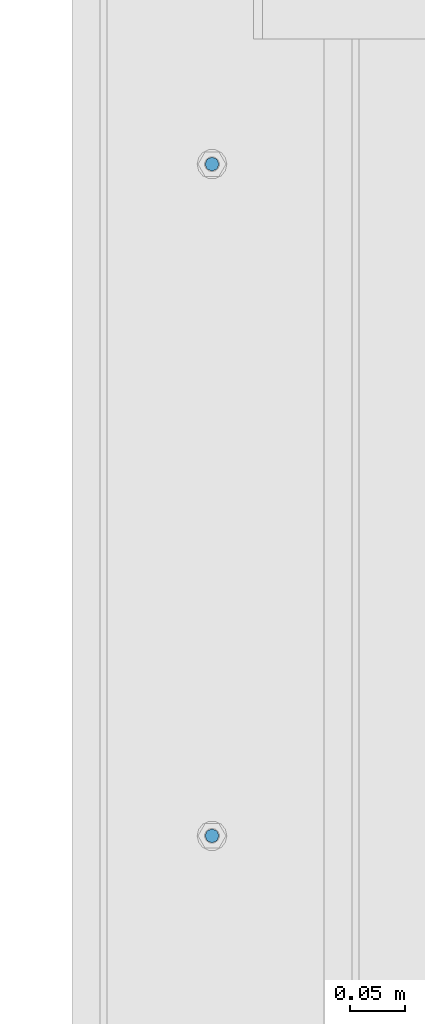
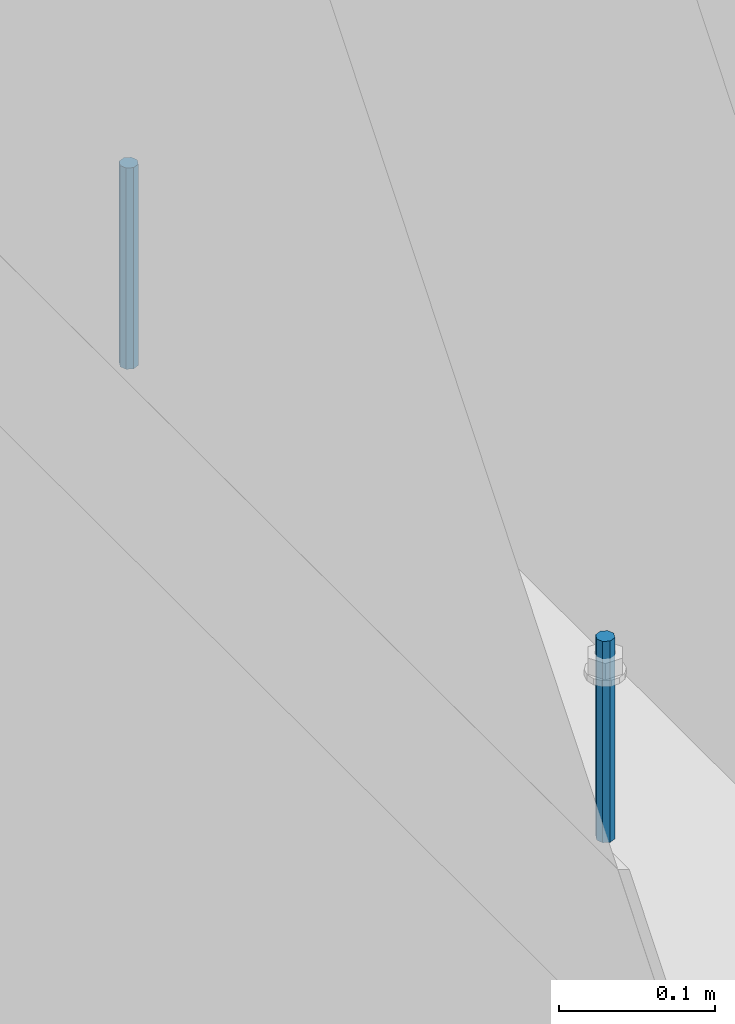
# One storey, part 383 of 1179: 2 columns, 1 element without a shape of its own.
"""IFC2X3 building model written with IfcOpenShell, lengths in millimetres."""

from ifc_helpers import new_model, si_unit, frame, origin_with_axes, place, context, subcontext, project, spatial, faceted_brep, material, type_object, element, aggregate, save


model = new_model("IFC2X3")

# Units and contexts
model_context = context("Model", 3, precision=1e-05, world=origin_with_axes())
body_context = subcontext(model_context, "Body", "Model", "MODEL_VIEW")
ifc_project = project(units=[si_unit("LENGTHUNIT", "METRE", prefix="MILLI"), si_unit("AREAUNIT", "SQUARE_METRE"), si_unit("VOLUMEUNIT", "CUBIC_METRE"), si_unit("MASSUNIT", "GRAM", prefix="KILO"), si_unit("TIMEUNIT", "SECOND"), si_unit("PLANEANGLEUNIT", "RADIAN"), si_unit("SOLIDANGLEUNIT", "STERADIAN"), si_unit("THERMODYNAMICTEMPERATUREUNIT", "DEGREE_CELSIUS"), si_unit("LUMINOUSINTENSITYUNIT", "LUMEN")], contexts=[model_context])

# Site, building, storey
site_placement = place(None, origin_with_axes())
site = spatial("IfcSite", under=ifc_project, at=site_placement, CompositionType="ELEMENT")
building_placement = place(site_placement, origin_with_axes())
building = spatial("IfcBuilding", under=site, at=building_placement, Name="Undefined", CompositionType="ELEMENT")
storey_placement = place(building_placement, origin_with_axes())
storey = spatial("IfcBuildingStorey", under=building, at=storey_placement, Name="Undefined", CompositionType="ELEMENT", Elevation=0.0)

# Assembly, columns
assembly_placement = place(storey_placement, origin_with_axes())
assembly = element("IfcElementAssembly", 1, at=assembly_placement, inside=storey, Name="BEAM", AssemblyPlace="NOTDEFINED", PredefinedType="RIGID_FRAME")
ifc_material = material(Name="STEEL/A307")
column_type = type_object("IfcColumnType", PredefinedType="NOTDEFINED")
column_1_placement = place(assembly_placement, frame((101.599999999999, 7626.34975, 4108.45), z_axis=(0.0, 1.0, 0.0), x_axis=(0.0, 0.0, 1.0)))
column_1 = element("IfcColumn", 2, at=column_1_placement, type_object=column_type, material=ifc_material, Name="THREADED ROD", context=body_context, shape_type="Brep", body=[
    faceted_brep([(0.0, -6.34999999999854, 0.0), (0.0, -4.49012806053361, -4.49012806053452), (157.162499999999, -4.49012806053361, -4.49012806053361), (157.162499999999, -6.34999999999854, 0.0), (0.0, 0.0, -6.34999999999991), (157.162499999999, 0.0, -6.34999999999854), (0.0, 4.49012806053361, -4.49012806053452), (157.162499999999, 4.49012806053361, -4.49012806053361), (0.0, 6.34999999999854, 0.0), (157.162499999999, 6.34999999999854, 0.0), (0.0, 4.49012806053361, 4.49012806053452), (157.162499999999, 4.49012806053361, 4.49012806053361), (0.0, 0.0, 6.34999999999991), (157.162499999999, 0.0, 6.34999999999854), (0.0, -4.49012806053361, 4.49012806053452), (157.162499999999, -4.49012806053361, 4.49012806053361)], [[[0, 1, 2, 3]], [[1, 4, 5, 2]], [[4, 6, 7, 5]], [[6, 8, 9, 7]], [[8, 10, 11, 9]], [[10, 12, 13, 11]], [[12, 14, 15, 13]], [[14, 0, 3, 15]], [[5, 7, 9, 11, 13, 15, 3, 2]], [[14, 12, 10, 8, 6, 4, 1, 0]]]),
])
column_2_placement = place(assembly_placement, frame((101.599999999999, 7016.74975, 4108.45), z_axis=(0.0, 1.0, 0.0), x_axis=(0.0, 0.0, 1.0)))
column_2 = element("IfcColumn", 3, at=column_2_placement, type_object=column_type, material=ifc_material, Name="THREADED ROD", context=body_context, shape_type="Brep", body=[
    faceted_brep([(0.0, -6.34999999999854, 0.0), (0.0, -4.49012806053361, -4.49012806053452), (157.162499999999, -4.49012806053361, -4.49012806053361), (157.162499999999, -6.34999999999854, 0.0), (0.0, 0.0, -6.34999999999991), (157.162499999999, 0.0, -6.34999999999854), (0.0, 4.49012806053361, -4.49012806053452), (157.162499999999, 4.49012806053361, -4.49012806053361), (0.0, 6.34999999999854, 0.0), (157.162499999999, 6.34999999999854, 0.0), (0.0, 4.49012806053361, 4.49012806053452), (157.162499999999, 4.49012806053361, 4.49012806053361), (0.0, 0.0, 6.34999999999991), (157.162499999999, 0.0, 6.34999999999854), (0.0, -4.49012806053361, 4.49012806053452), (157.162499999999, -4.49012806053361, 4.49012806053361)], [[[0, 1, 2, 3]], [[1, 4, 5, 2]], [[4, 6, 7, 5]], [[6, 8, 9, 7]], [[8, 10, 11, 9]], [[10, 12, 13, 11]], [[12, 14, 15, 13]], [[14, 0, 3, 15]], [[5, 7, 9, 11, 13, 15, 3, 2]], [[14, 12, 10, 8, 6, 4, 1, 0]]]),
])
aggregate(assembly, [column_1, column_2])

save(model, "model.ifc")
